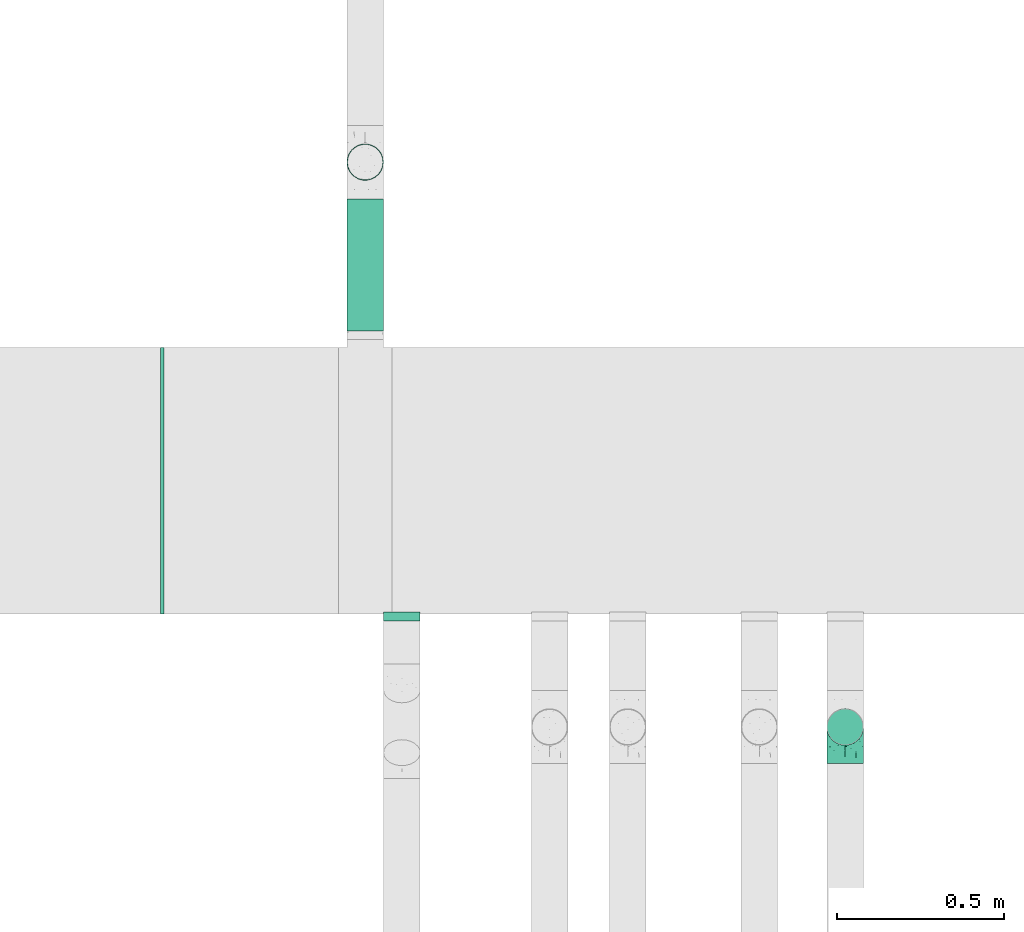
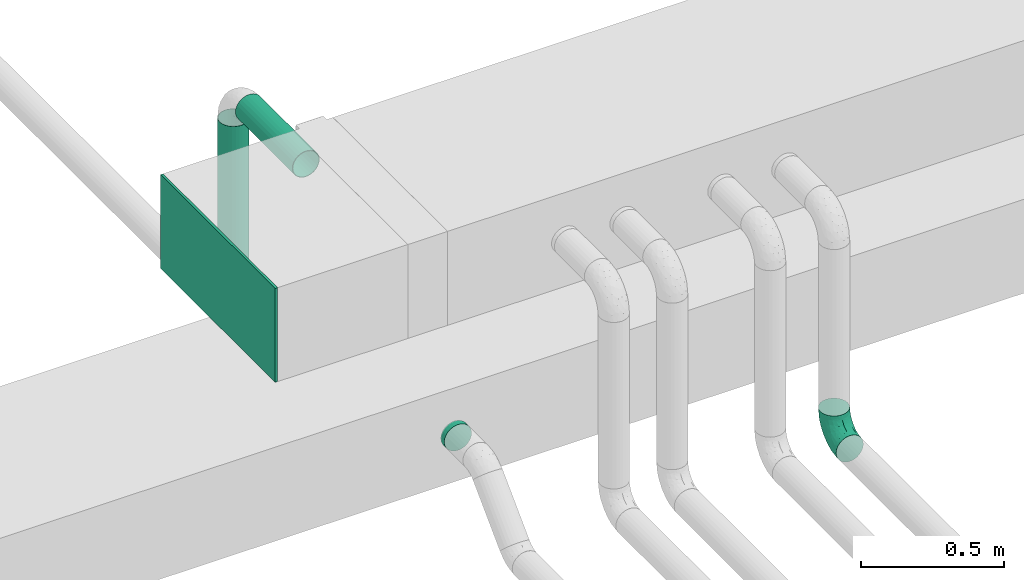
# One storey, part 12 of 91: 3 flow fittings, 2 flow segments.
"""IFC2X3 building model written with IfcOpenShell, lengths in millimetres."""

from ifc_helpers import new_model, entity, si_unit, converted_unit, derived_unit, direction, frame, origin_with_axes, origin_2d_with_axis, place, context, subcontext, project, spatial, hollow_circle, extrude, open_shell, surface_model, source, transform, mapped, material, layer, layer_set, layer_usage, type_object, element, save


model = new_model("IFC2X3")

# Units and contexts
model_context = context("Model", 3, precision=1e-05, world=origin_with_axes(), true_north=direction((0.0, 1.0)))
body_context = subcontext(model_context, "Body", "Model", "MODEL_VIEW")
ifc_project = project(units=[si_unit("AREAUNIT", "SQUARE_METRE"), si_unit("VOLUMEUNIT", "CUBIC_METRE", prefix="DECI"), si_unit("TIMEUNIT", "SECOND"), si_unit("THERMODYNAMICTEMPERATUREUNIT", "DEGREE_CELSIUS"), si_unit("PRESSUREUNIT", "PASCAL"), si_unit("MASSUNIT", "GRAM", prefix="KILO"), si_unit("LENGTHUNIT", "METRE", prefix="MILLI"), si_unit("POWERUNIT", "WATT"), si_unit("ELECTRICCURRENTUNIT", "AMPERE"), si_unit("ELECTRICVOLTAGEUNIT", "VOLT"), derived_unit("VOLUMETRICFLOWRATEUNIT", [(si_unit("VOLUMEUNIT", "CUBIC_METRE", prefix="DECI"), 1), (si_unit("TIMEUNIT", "SECOND"), -1)]), derived_unit("LINEARVELOCITYUNIT", [(si_unit("LENGTHUNIT", "METRE"), 1), (si_unit("TIMEUNIT", "SECOND"), -1)]), derived_unit("MASSDENSITYUNIT", [(si_unit("MASSUNIT", "GRAM", prefix="KILO"), 1), (si_unit("VOLUMEUNIT", "CUBIC_METRE"), -1)]), converted_unit("PLANEANGLEUNIT", "DEGREE", entity("IfcRatioMeasure", 0.01745), si_unit("PLANEANGLEUNIT", "RADIAN"), dimensions=[0, 0, 0, 0, 0, 0, 0])], contexts=[model_context])

# Site, building, storey
site_placement = place(None, origin_with_axes())
site = spatial("IfcSite", under=ifc_project, at=site_placement, CompositionType="ELEMENT")
building_placement = place(site_placement, origin_with_axes())
building = spatial("IfcBuilding", under=site, at=building_placement, Name="mc-building", CompositionType="ELEMENT")
storey_placement = place(building_placement, frame((0.0, 0.0, 8700.0), z_axis=(0.0, 0.0, 1.0), x_axis=(1.0, 0.0, 0.0)))
storey = spatial("IfcBuildingStorey", under=building, at=storey_placement, CompositionType="ELEMENT", Elevation=8700.0)

# Flow segment
ifc_material = material(Name="FZ1")
ifc_layer = layer(ifc_material, 0.0)
ifc_layer_set = layer_set([ifc_layer], Name="FZ1")
ifc_layer_usage = layer_usage(ifc_layer_set, "AXIS1", "POSITIVE", 0.0)
duct_segment_type = type_object("IfcDuctSegmentType", PredefinedType="RIGIDSEGMENT")
shared_shape_1 = source(origin_with_axes(), body_context, "Body", "SweptSolid", [
    extrude(hollow_circle(Radius=55.0, WallThickness=2.0, at=origin_2d_with_axis()), frame((0.0, 0.0, 0.0), z_axis=(1.0, 0.0, 0.0), x_axis=(0.0, 1.0, 0.0)), (0.0, 0.0, 1.0), 709.0),
])
flow_segment_1_placement = place(storey_placement, frame((7804.24801, 4308.04257, 1234.0), z_axis=(0.0, 1.0, 0.0), x_axis=(0.0, 0.0, -1.0)))
element("IfcFlowSegment", 1, at=flow_segment_1_placement, inside=storey, type_object=duct_segment_type, material=ifc_layer_usage, context=body_context, shape_type="MappedRepresentation", body=[
    mapped(shared_shape_1, transform((0.0, 0.0, 0.0), scale=1.0)),
])

# Flow fittings
duct_fitting_type_1 = type_object("IfcDuctFittingType", Name="BU", PredefinedType="BEND")
shared_shape_2 = source(origin_with_axes(), body_context, "Body", "SurfaceModel", [
    surface_model("IfcShellBasedSurfaceModel", [(-110.0, 0.0, -55.0), (-110.0, -14.23505, -53.12592), (-110.0, 14.23505, -53.12592), (-110.0, 53.12592, 14.23505), (-110.0, 27.5, -47.63139), (-110.0, 38.89087, -38.89087), (-110.0, -55.0, 0.0), (-110.0, -53.12592, 14.23505), (-110.0, -38.89087, -38.89087), (-110.0, -27.5, -47.63139), (-110.0, -53.12592, -14.23505), (-110.0, -47.63139, -27.5), (-110.0, -14.23505, 53.12592), (-110.0, 14.23505, 53.12592), (-110.0, 27.5, 47.63139), (-110.0, -47.63139, 27.5), (-110.0, -38.89087, 38.89087), (-110.0, -27.5, 47.63139), (-110.0, 0.0, 55.0), (-110.0, 55.0, 0.0), (-110.0, 53.12592, -14.23505), (-110.0, 47.63139, -27.5), (-110.0, 47.63139, 27.5), (-110.0, 38.89087, 38.89087), (-14.23505, 110.0, -53.12592), (-55.0, 110.0, 0.0), (0.0, 110.0, -55.0), (-27.5, 110.0, -47.63139), (-38.89087, 110.0, -38.89087), (-47.63139, 110.0, -27.5), (38.89087, 110.0, -38.89087), (53.12592, 110.0, 14.23505), (27.5, 110.0, -47.63139), (14.23505, 110.0, -53.12592), (47.63139, 110.0, -27.5), (53.12592, 110.0, -14.23505), (55.0, 110.0, 0.0), (-53.12592, 110.0, -14.23505), (-53.12592, 110.0, 14.23505), (-47.63139, 110.0, 27.5), (-38.89087, 110.0, 38.89087), (-27.5, 110.0, 47.63139), (0.0, 110.0, 55.0), (-14.23505, 110.0, 53.12592), (38.89087, 110.0, 38.89087), (47.63139, 110.0, 27.5), (27.5, 110.0, 47.63139), (14.23505, 110.0, 53.12592), (-64.21732, 48.68956, 43.63444), (-76.6405, 38.18013, 45.55988), (-60.44912, 32.56953, 51.94617), (-76.00813, 5.38378, 55.0), (-90.15553, 11.94394, 54.09138), (-78.5998, 26.77405, 50.81338), (-70.18771, 18.55163, 54.03432), (-75.55424, 54.2118, 32.41257), (-93.27622, 45.77614, 33.48188), (-96.12334, 22.13664, 50.81337), (-21.00813, 45.34362, 55.0), (-18.36258, 70.48427, 54.04484), (-32.04182, 59.64019, 52.24446), (-63.88653, 74.77858, 17.99134), (-74.66383, 63.08407, 19.92123), (-63.60674, 66.07878, 29.97482), (-99.597, 52.72185, 18.52927), (-93.11138, 56.59448, 10.50359), (-98.21577, 57.34403, 0.0), (-53.42855, 92.60092, 21.04759), (-88.54852, 54.8376, 21.04759), (-11.86161, 90.23965, 54.10313), (-5.38378, 76.00813, 55.0), (-57.34403, 98.21577, 0.0), (-56.64619, 93.12774, 10.22088), (-45.34362, 21.00813, 55.0), (-44.60838, 44.60838, 52.13415), (-92.68484, 35.46673, 43.63443), (-22.25266, 95.40765, 50.81337), (-35.97783, 90.61597, 43.63443), (-43.70931, 69.58671, 44.47149), (-27.23711, 77.39884, 50.81337), (-57.2828, 79.3123, 24.9774), (-58.67786, 84.31125, 16.04456), (-82.93277, 60.36161, 12.91784), (-49.88337, 54.51816, 47.224), (-74.57753, 66.83759, 9.55742), (-45.35812, 94.97281, 33.48188), (-59.18663, 88.95241, 0.0), (-51.517, 78.6292, 33.48188), (-65.14788, 80.03077, 0.0), (-56.45322, 62.06476, 39.63545), (-88.95241, 59.18663, 0.0), (-71.10913, 71.10913, 0.0), (-80.03077, 65.14788, 0.0), (-94.9309, 45.36788, -33.48188), (-93.11358, 56.60141, -10.46614), (-99.64997, 52.79499, -18.30015), (-90.20425, 36.08686, -43.63443), (-79.99933, 46.56772, -37.92748), (-76.00813, 5.38378, -55.0), (-72.75364, 19.68651, -53.60527), (-45.34362, 21.00813, -55.0), (-21.91957, 65.12078, -53.85897), (-5.38378, 76.00813, -55.0), (-21.00813, 45.34362, -55.0), (-35.41876, 92.89265, -43.63443), (-91.10309, 11.02766, -54.21832), (-45.77614, 93.27622, -33.48188), (-90.50474, 23.21022, -50.81337), (-70.92854, 33.31794, -49.51754), (-78.52933, 63.35627, -11.73997), (-24.91508, 84.05606, -50.81337), (-88.78941, 54.74452, -21.04759), (-69.59921, 57.34866, -33.48187), (-73.36422, 62.46673, -22.94182), (-63.49062, 67.59111, -28.46929), (-56.59448, 93.11138, -10.50359), (-54.8376, 88.54852, -21.04759), (-54.10679, 75.85581, -32.31867), (-57.75956, 31.09612, -52.80882), (-52.72185, 99.597, -18.52927), (-12.62913, 89.46304, -53.99097), (-34.46825, 66.46123, -50.04329), (-43.9837, 43.9837, -52.42279), (-65.78527, 72.58348, -17.68796), (-70.34468, 43.65295, -44.21951), (-57.47001, 51.99467, -44.91465), (-60.72547, 82.29174, -12.88567), (-42.34915, 74.24548, -43.63444), (-57.25194, 63.5016, -38.08211), (-80.95344, 53.56991, -29.32027), (-52.32891, 4.55257, -54.0482), (32.52942, 47.13398, -30.48571), (14.88266, 20.92917, -33.7947), (14.95561, 36.05775, -42.26543), (30.24048, 70.09027, -41.7461), (19.3559, 65.35825, -48.00507), (-70.35075, -46.44478, -19.5952), (-47.13398, -32.52942, -30.48571), (-28.49299, -30.5778, -16.4009), (-4.55257, 52.32891, -54.0482), (-22.4954, 22.4954, -53.25347), (-75.47368, -11.22546, -52.60718), (-81.32209, -51.5606, -9.98467), (-80.81763, -41.84862, -32.14655), (-70.09027, -30.24048, -41.7461), (-36.05774, -14.95561, -42.26543), (-9.15831, -10.852, -27.8997), (-65.35825, -19.3559, -48.00507), (11.22546, 75.47368, -52.60718), (3.94376, 43.9333, -50.53315), (-13.39742, 13.39743, -48.13058), (-43.9333, -3.94376, -50.53315), (49.37776, 67.29486, 0.0), (41.8609, 47.82256, -9.92641), (50.20582, 74.51695, -9.9731), (18.93131, 11.7156, -17.56239), (-27.5, -32.89419, 0.0), (-1.23348, -12.25375, -12.18106), (41.84862, 80.81763, -32.14655), (35.70604, 41.31408, -20.38235), (46.44478, 70.35075, -19.5952), (32.89419, 27.5, 0.0), (6.67262, -6.67262, 0.0), (-67.29486, -49.37776, 0.0), (-50.36265, -42.95545, -9.51562), (-5.47251, 5.47251, -39.92906), (-70.35075, -46.44478, 19.5952), (-74.51695, -50.20582, 9.9731), (-41.31407, -35.70604, 20.38235), (-47.13398, -32.52942, 30.48571), (-80.81763, -41.84862, 32.14655), (-4.55257, 52.32891, 54.0482), (11.22546, 75.47368, 52.60718), (-43.9333, -3.94376, 50.53315), (-65.35825, -19.3559, 48.00507), (-36.05774, -14.95561, 42.26543), (-70.09027, -30.24048, 41.7461), (-11.7156, -18.93131, 17.56239), (30.5778, 28.49299, 16.4009), (12.25375, 1.23348, 12.18106), (51.5606, 81.32209, 9.98467), (42.95545, 50.36265, 9.51562), (-75.47368, -11.22546, 52.60718), (-52.32891, 4.55257, 54.0482), (3.94376, 43.9333, 50.53315), (-22.4954, 22.4954, 53.25347), (-13.39742, 13.39743, 48.13058), (10.852, 9.15831, 27.8997), (-20.92916, -14.88266, 33.79469), (-47.82256, -41.8609, 9.92641), (32.52942, 47.13398, 30.48571), (46.44478, 70.35075, 19.5952), (41.84862, 80.81763, 32.14655), (30.24048, 70.09027, 41.7461), (19.3559, 65.35825, 48.00507), (14.95561, 36.05775, 42.26543), (-5.47251, 5.47251, 39.92906)], [open_shell([[[0, 1, 2]], [[2, 3, 4]], [[4, 3, 5]], [[2, 6, 7]], [[8, 6, 9]], [[1, 9, 6]], [[10, 6, 11]], [[8, 11, 6]], [[6, 2, 1]], [[12, 13, 14]], [[15, 2, 7]], [[16, 17, 2]], [[2, 17, 12]], [[12, 18, 13]], [[19, 20, 3]], [[5, 3, 21]], [[20, 21, 3]], [[22, 3, 2]], [[23, 22, 2]], [[12, 14, 2]], [[2, 14, 23]], [[15, 16, 2]], [[24, 25, 26]], [[27, 25, 24]], [[25, 28, 29]], [[28, 25, 27]], [[30, 26, 31]], [[26, 30, 32]], [[32, 33, 26]], [[34, 31, 35]], [[31, 34, 30]], [[35, 31, 36]], [[29, 37, 25]], [[38, 39, 26]], [[39, 40, 26]], [[41, 42, 40]], [[42, 26, 40]], [[42, 41, 43]], [[26, 44, 45]], [[31, 26, 45]], [[26, 46, 44]], [[47, 46, 26]], [[42, 47, 26]], [[25, 38, 26]], [[48, 49, 50]], [[18, 51, 52]], [[53, 54, 50]], [[55, 56, 49]], [[56, 22, 23]], [[13, 57, 14]], [[58, 59, 60]], [[61, 62, 63]], [[3, 64, 65]], [[53, 52, 54]], [[3, 65, 66]], [[67, 39, 38]], [[56, 68, 64]], [[65, 64, 68]], [[69, 59, 70]], [[38, 71, 72]], [[73, 58, 74]], [[75, 49, 56]], [[76, 69, 43]], [[53, 57, 52]], [[77, 78, 79]], [[41, 76, 43]], [[43, 69, 42]], [[55, 68, 56]], [[23, 14, 75]], [[76, 77, 79]], [[80, 67, 81]], [[62, 82, 68]], [[60, 78, 83]], [[62, 84, 82]], [[85, 77, 40]], [[81, 67, 72]], [[86, 72, 71]], [[87, 85, 67]], [[61, 81, 88]], [[77, 41, 40]], [[78, 77, 87]], [[23, 75, 56]], [[83, 89, 48]], [[85, 40, 39]], [[62, 68, 55]], [[89, 87, 63]], [[83, 48, 50]], [[57, 75, 14]], [[49, 75, 53]], [[67, 85, 39]], [[87, 77, 85]], [[63, 62, 55]], [[89, 55, 48]], [[80, 63, 87]], [[66, 65, 90]], [[66, 19, 3]], [[84, 91, 92]], [[92, 90, 82]], [[65, 82, 90]], [[61, 84, 62]], [[92, 82, 84]], [[68, 82, 65]], [[3, 22, 64]], [[56, 64, 22]], [[38, 25, 71]], [[81, 72, 86]], [[38, 72, 67]], [[91, 61, 88]], [[80, 81, 61]], [[63, 80, 61]], [[67, 80, 87]], [[77, 76, 41]], [[79, 59, 69]], [[79, 69, 76]], [[42, 69, 70]], [[60, 59, 79]], [[58, 70, 59]], [[78, 60, 79]], [[58, 60, 74]], [[52, 57, 13]], [[75, 57, 53]], [[18, 52, 13]], [[52, 51, 54]], [[51, 73, 54]], [[50, 73, 74]], [[73, 50, 54]], [[50, 74, 83]], [[60, 83, 74]], [[89, 83, 78]], [[87, 89, 78]], [[55, 89, 63]], [[50, 49, 53]], [[55, 49, 48]], [[81, 86, 88]], [[91, 84, 61]], [[5, 21, 93]], [[90, 94, 66]], [[20, 94, 95]], [[96, 93, 97]], [[98, 99, 100]], [[96, 4, 5]], [[101, 102, 103]], [[28, 27, 104]], [[2, 105, 0]], [[104, 106, 28]], [[99, 105, 107]], [[108, 107, 96]], [[90, 109, 94]], [[107, 2, 4]], [[20, 66, 94]], [[27, 24, 110]], [[109, 111, 94]], [[112, 113, 114]], [[37, 115, 71]], [[116, 106, 117]], [[99, 118, 100]], [[116, 115, 119]], [[37, 119, 115]], [[24, 120, 110]], [[121, 110, 101]], [[119, 106, 116]], [[101, 110, 120]], [[122, 103, 100]], [[117, 123, 116]], [[124, 125, 108]], [[115, 116, 126]], [[106, 29, 28]], [[26, 102, 120]], [[127, 104, 110]], [[97, 124, 96]], [[125, 122, 118]], [[128, 127, 125]], [[96, 5, 93]], [[115, 126, 86]], [[117, 106, 127]], [[111, 113, 129]], [[95, 93, 21]], [[97, 129, 112]], [[110, 104, 27]], [[106, 104, 127]], [[96, 107, 4]], [[99, 107, 108]], [[99, 108, 118]], [[105, 99, 98]], [[112, 114, 128]], [[121, 125, 127]], [[20, 19, 66]], [[109, 90, 92]], [[94, 111, 95]], [[91, 123, 109]], [[129, 113, 112]], [[93, 95, 111]], [[21, 20, 95]], [[71, 115, 86]], [[71, 25, 37]], [[123, 91, 88]], [[126, 116, 123]], [[123, 88, 126]], [[86, 126, 88]], [[37, 29, 119]], [[106, 119, 29]], [[129, 93, 111]], [[124, 112, 125]], [[0, 105, 98]], [[107, 105, 2]], [[125, 118, 108]], [[100, 118, 122]], [[93, 129, 97]], [[113, 111, 109]], [[109, 123, 113]], [[114, 123, 117]], [[123, 114, 113]], [[128, 114, 117]], [[127, 128, 117]], [[112, 128, 125]], [[103, 122, 101]], [[110, 121, 127]], [[101, 122, 121]], [[125, 121, 122]], [[26, 120, 24]], [[101, 120, 102]], [[96, 124, 108]], [[92, 91, 109]], [[112, 124, 97]], [[100, 130, 98]], [[131, 132, 133]], [[32, 134, 135]], [[136, 137, 138]], [[139, 140, 103]], [[98, 141, 0]], [[142, 10, 136]], [[143, 144, 137]], [[6, 10, 142]], [[137, 145, 146]], [[144, 147, 145]], [[143, 136, 11]], [[11, 136, 10]], [[8, 143, 11]], [[148, 149, 139]], [[8, 9, 144]], [[9, 1, 147]], [[130, 141, 98]], [[103, 140, 100]], [[148, 135, 149]], [[150, 151, 140]], [[152, 153, 154]], [[130, 140, 151]], [[148, 26, 33]], [[147, 1, 141]], [[155, 146, 132]], [[156, 138, 157]], [[134, 30, 158]], [[150, 140, 149]], [[158, 30, 34]], [[30, 134, 32]], [[153, 159, 160]], [[131, 160, 159]], [[144, 145, 137]], [[36, 152, 154]], [[146, 138, 137]], [[155, 161, 162]], [[158, 160, 131]], [[133, 149, 135]], [[156, 163, 164]], [[163, 142, 164]], [[139, 103, 102]], [[153, 152, 161]], [[34, 35, 160]], [[162, 157, 155]], [[132, 165, 133]], [[157, 146, 155]], [[140, 130, 100]], [[141, 130, 151]], [[141, 151, 147]], [[141, 1, 0]], [[102, 26, 148]], [[140, 139, 149]], [[102, 148, 139]], [[135, 33, 32]], [[151, 150, 145]], [[9, 147, 144]], [[151, 145, 147]], [[145, 165, 146]], [[135, 148, 33]], [[133, 135, 134]], [[131, 133, 134]], [[133, 165, 150]], [[133, 150, 149]], [[145, 150, 165]], [[132, 131, 159]], [[146, 165, 132]], [[160, 158, 34]], [[134, 158, 131]], [[144, 143, 8]], [[136, 143, 137]], [[155, 153, 161]], [[154, 153, 160]], [[153, 155, 159]], [[132, 159, 155]], [[160, 35, 154]], [[36, 154, 35]], [[164, 136, 138]], [[6, 142, 163]], [[136, 164, 142]], [[156, 164, 138]], [[156, 157, 162]], [[146, 157, 138]], [[15, 7, 166]], [[6, 163, 167]], [[168, 169, 166]], [[166, 169, 170]], [[171, 172, 70]], [[173, 174, 175]], [[17, 176, 174]], [[177, 156, 162]], [[176, 16, 170]], [[170, 16, 15]], [[161, 178, 179]], [[152, 180, 181]], [[182, 173, 183]], [[18, 12, 182]], [[184, 185, 186]], [[183, 185, 73]], [[183, 73, 51]], [[177, 187, 188]], [[189, 168, 166]], [[187, 178, 190]], [[16, 176, 17]], [[161, 152, 181]], [[45, 191, 31]], [[45, 44, 192]], [[192, 191, 45]], [[180, 36, 31]], [[193, 194, 195]], [[46, 47, 194]], [[193, 195, 190]], [[193, 44, 46]], [[172, 42, 70]], [[185, 58, 73]], [[189, 163, 156]], [[163, 189, 167]], [[70, 58, 171]], [[184, 171, 185]], [[169, 188, 175]], [[180, 31, 191]], [[192, 193, 190]], [[191, 190, 178]], [[182, 174, 173]], [[194, 47, 172]], [[190, 195, 187]], [[186, 185, 173]], [[162, 179, 177]], [[188, 196, 175]], [[179, 187, 177]], [[185, 171, 58]], [[172, 171, 184]], [[172, 184, 194]], [[172, 47, 42]], [[51, 18, 182]], [[185, 183, 173]], [[51, 182, 183]], [[174, 12, 17]], [[184, 186, 195]], [[46, 194, 193]], [[184, 195, 194]], [[195, 196, 187]], [[174, 182, 12]], [[175, 174, 176]], [[169, 175, 176]], [[175, 196, 186]], [[175, 186, 173]], [[195, 186, 196]], [[188, 169, 168]], [[187, 196, 188]], [[166, 170, 15]], [[176, 170, 169]], [[193, 192, 44]], [[191, 192, 190]], [[177, 189, 156]], [[167, 189, 166]], [[189, 177, 168]], [[188, 168, 177]], [[166, 7, 167]], [[6, 167, 7]], [[181, 191, 178]], [[36, 180, 152]], [[191, 181, 180]], [[161, 181, 178]], [[161, 179, 162]], [[187, 179, 178]]])]),
])
flow_fitting_1_placement = place(storey_placement, frame((9245.0, 2612.35324, 415.0), z_axis=(1.0, 0.0, 0.0), x_axis=(0.0, 1.0, 0.0)))
element("IfcFlowFitting", 2, at=flow_fitting_1_placement, inside=storey, type_object=duct_fitting_type_1, Name="BU", context=body_context, shape_type="MappedRepresentation", body=[
    mapped(shared_shape_2, transform((0.0, 0.0, 0.0), scale=1.0)),
])
duct_fitting_type_2 = type_object("IfcDuctFittingType", Name="CC", PredefinedType="CONNECTOR")
shared_shape_3 = source(origin_with_axes(), body_context, "Body", "SurfaceModel", [
    surface_model("IfcShellBasedSurfaceModel", [(-6.096, -55.0, 0.0), (-6.096, 0.0, -55.0), (-6.096, -14.23505, -53.12592), (-6.096, -27.5, -47.63139), (-6.096, -38.89087, -38.89087), (-6.096, -47.63139, -27.5), (-6.096, 38.89087, -38.89087), (-6.096, 53.12592, 14.23505), (-6.096, 27.5, -47.63139), (-6.096, 14.23505, -53.12592), (-6.096, 47.63139, -27.5), (-6.096, 53.12592, -14.23505), (-6.096, 55.0, 0.0), (-6.096, -53.12592, -14.23505), (-6.096, -53.12592, 14.23505), (-6.096, -47.63139, 27.5), (-6.096, -38.89087, 38.89087), (-6.096, 0.0, 55.0), (-6.096, -27.5, 47.63139), (-6.096, -14.23505, 53.12592), (-6.096, 38.89087, 38.89087), (-6.096, 47.63139, 27.5), (-6.096, 14.23505, 53.12592), (-6.096, 27.5, 47.63139), (0.0, -14.23505, 53.12592), (0.0, 0.0, 55.0), (0.0, -27.5, 47.63139), (0.0, -38.89087, 38.89087), (0.0, -53.12592, 14.23505), (0.0, -47.63139, 27.5), (0.0, -55.0, 0.0), (0.0, -53.12592, -14.23505), (0.0, -47.63139, -27.5), (0.0, -38.89087, -38.89087), (0.0, -14.23505, -53.12592), (0.0, -27.5, -47.63139), (0.0, 0.0, -55.0), (0.0, 14.23505, -53.12592), (0.0, 27.5, -47.63139), (0.0, 38.89087, -38.89087), (0.0, 53.12592, -14.23505), (0.0, 47.63139, -27.5), (0.0, 55.0, 0.0), (0.0, 53.12592, 14.23505), (0.0, 47.63139, 27.5), (0.0, 38.89087, 38.89087), (0.0, 14.23505, 53.12592), (0.0, 27.5, 47.63139), (20.0, 0.0, -55.0), (20.0, 14.23505, -53.12592), (20.0, -14.23505, -53.12592), (20.0, -53.12592, 14.23505), (20.0, -27.5, -47.63139), (20.0, -47.63139, -27.5), (20.0, -38.89087, -38.89087), (20.0, 55.0, 0.0), (20.0, 53.12592, 14.23505), (20.0, 38.89087, -38.89087), (20.0, 27.5, -47.63139), (20.0, 53.12592, -14.23505), (20.0, 47.63139, -27.5), (20.0, -53.12592, -14.23505), (20.0, -47.63139, 27.5), (20.0, -38.89087, 38.89087), (20.0, 14.23505, 53.12592), (20.0, -27.5, 47.63139), (20.0, -14.23505, 53.12592), (20.0, 47.63139, 27.5), (20.0, 38.89087, 38.89087), (20.0, 27.5, 47.63139), (20.0, 0.0, 55.0), (20.0, -55.0, 0.0)], [open_shell([[[0, 1, 2]], [[3, 0, 2]], [[0, 4, 5]], [[4, 0, 3]], [[6, 1, 7]], [[1, 6, 8]], [[8, 9, 1]], [[6, 7, 10]], [[10, 7, 11]], [[12, 11, 7]], [[13, 0, 5]], [[14, 15, 1]], [[1, 15, 16]], [[17, 16, 18]], [[17, 1, 16]], [[19, 17, 18]], [[20, 21, 1]], [[7, 1, 21]], [[22, 23, 1]], [[23, 20, 1]], [[22, 1, 17]], [[0, 14, 1]], [[24, 25, 17]], [[26, 24, 19]], [[19, 24, 17]], [[16, 27, 18]], [[26, 19, 18]], [[26, 18, 27]], [[28, 29, 15]], [[30, 28, 14]], [[15, 29, 16]], [[28, 15, 14]], [[30, 14, 0]], [[27, 16, 29]], [[31, 30, 0]], [[32, 31, 13]], [[13, 31, 0]], [[4, 33, 5]], [[32, 13, 5]], [[32, 5, 33]], [[34, 35, 3]], [[36, 34, 2]], [[3, 35, 4]], [[34, 3, 2]], [[36, 2, 1]], [[33, 4, 35]], [[37, 36, 1]], [[38, 37, 9]], [[9, 37, 1]], [[6, 39, 8]], [[38, 9, 8]], [[38, 8, 39]], [[40, 41, 10]], [[42, 40, 11]], [[10, 41, 6]], [[40, 10, 11]], [[42, 11, 12]], [[39, 6, 41]], [[43, 42, 12]], [[44, 43, 7]], [[7, 43, 12]], [[20, 45, 21]], [[44, 7, 21]], [[44, 21, 45]], [[46, 47, 23]], [[25, 46, 22]], [[23, 47, 20]], [[46, 23, 22]], [[25, 22, 17]], [[45, 20, 47]], [[48, 49, 50]], [[50, 51, 52]], [[53, 54, 51]], [[52, 51, 54]], [[50, 55, 56]], [[57, 55, 58]], [[49, 58, 55]], [[59, 55, 60]], [[57, 60, 55]], [[55, 50, 49]], [[53, 51, 61]], [[50, 62, 51]], [[63, 62, 50]], [[64, 65, 50]], [[65, 63, 50]], [[64, 66, 65]], [[50, 67, 68]], [[67, 50, 56]], [[68, 69, 50]], [[50, 69, 64]], [[64, 70, 66]], [[71, 61, 51]], [[66, 70, 25]], [[65, 66, 24]], [[24, 66, 25]], [[27, 63, 26]], [[65, 24, 26]], [[65, 26, 63]], [[51, 62, 29]], [[71, 51, 28]], [[29, 62, 27]], [[51, 29, 28]], [[71, 28, 30]], [[63, 27, 62]], [[61, 71, 30]], [[53, 61, 31]], [[31, 61, 30]], [[33, 54, 32]], [[53, 31, 32]], [[53, 32, 54]], [[50, 52, 35]], [[48, 50, 34]], [[35, 52, 33]], [[50, 35, 34]], [[48, 34, 36]], [[54, 33, 52]], [[49, 48, 36]], [[58, 49, 37]], [[37, 49, 36]], [[39, 57, 38]], [[58, 37, 38]], [[58, 38, 57]], [[59, 60, 41]], [[55, 59, 40]], [[41, 60, 39]], [[59, 41, 40]], [[55, 40, 42]], [[57, 39, 60]], [[56, 55, 42]], [[67, 56, 43]], [[43, 56, 42]], [[45, 68, 44]], [[67, 43, 44]], [[67, 44, 68]], [[64, 69, 47]], [[70, 64, 46]], [[47, 69, 45]], [[64, 47, 46]], [[70, 46, 25]], [[68, 45, 69]], [[50, 63, 62]], [[50, 64, 65]], [[50, 56, 67]], [[50, 68, 69]], [[64, 50, 69]]])]),
])
flow_fitting_2_placement = place(storey_placement, frame((7914.47808, 2951.20513, 668.0), z_axis=(0.0, 0.0, -1.0), x_axis=(0.0, -1.0, 0.0)))
element("IfcFlowFitting", 3, at=flow_fitting_2_placement, inside=storey, type_object=duct_fitting_type_2, Name="CC", context=body_context, shape_type="MappedRepresentation", body=[
    mapped(shared_shape_3, transform((0.0, 0.0, 0.0), scale=1.0)),
])
duct_fitting_type_3 = type_object("IfcDuctFittingType", Name="R", PredefinedType="OBSTRUCTION")
shared_shape_4 = source(origin_with_axes(), body_context, "Body", "SurfaceModel", [
    surface_model("IfcShellBasedSurfaceModel", [(0.0, 400.0, 200.0), (0.0, 400.0, -200.0), (0.0, -400.0, -200.0), (0.0, -400.0, 200.0), (10.0, -400.0, -200.0), (10.0, 400.0, -200.0), (10.0, -400.0, 200.0), (10.0, 400.0, 200.0)], [open_shell([[[0, 1, 2]], [[2, 3, 0]], [[4, 5, 6]], [[7, 6, 5]], [[1, 0, 7]], [[7, 5, 1]], [[2, 1, 5]], [[5, 4, 2]], [[3, 2, 4]], [[4, 6, 3]], [[0, 3, 7]], [[6, 7, 3]]])]),
])
flow_fitting_3_placement = place(storey_placement, frame((7200.0, 3351.20513, 1344.0), z_axis=(0.0, 0.0, 1.0), x_axis=(-1.0, 0.0, 0.0)))
element("IfcFlowFitting", 4, at=flow_fitting_3_placement, inside=storey, type_object=duct_fitting_type_3, Name="R", context=body_context, shape_type="MappedRepresentation", body=[
    mapped(shared_shape_4, transform((0.0, 0.0, 0.0), scale=1.0)),
])

# Flow segment
shared_shape_5 = source(origin_with_axes(), body_context, "Body", "SweptSolid", [
    extrude(hollow_circle(Radius=55.0, WallThickness=2.0, at=origin_2d_with_axis()), frame((0.0, 0.0, 0.0), z_axis=(1.0, 0.0, 0.0), x_axis=(0.0, 1.0, 0.0)), (0.0, 0.0, 1.0), 396.8),
])
flow_segment_2_placement = place(storey_placement, frame((7804.24801, 3801.20513, 1344.0), z_axis=(0.0, 0.0, 1.0), x_axis=(0.0, 1.0, 0.0)))
element("IfcFlowSegment", 5, at=flow_segment_2_placement, inside=storey, type_object=duct_segment_type, material=ifc_layer_usage, context=body_context, shape_type="MappedRepresentation", body=[
    mapped(shared_shape_5, transform((0.0, 0.0, 0.0), scale=1.0)),
])

save(model, "model.ifc")
